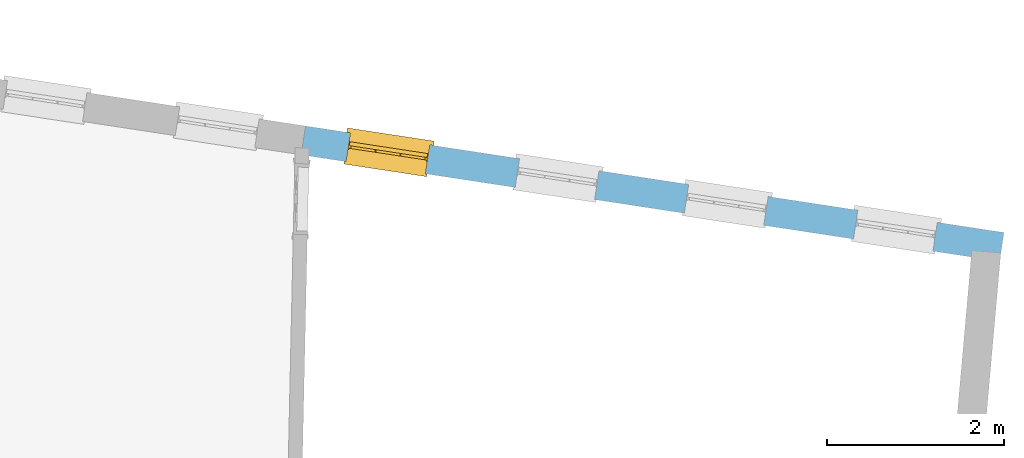
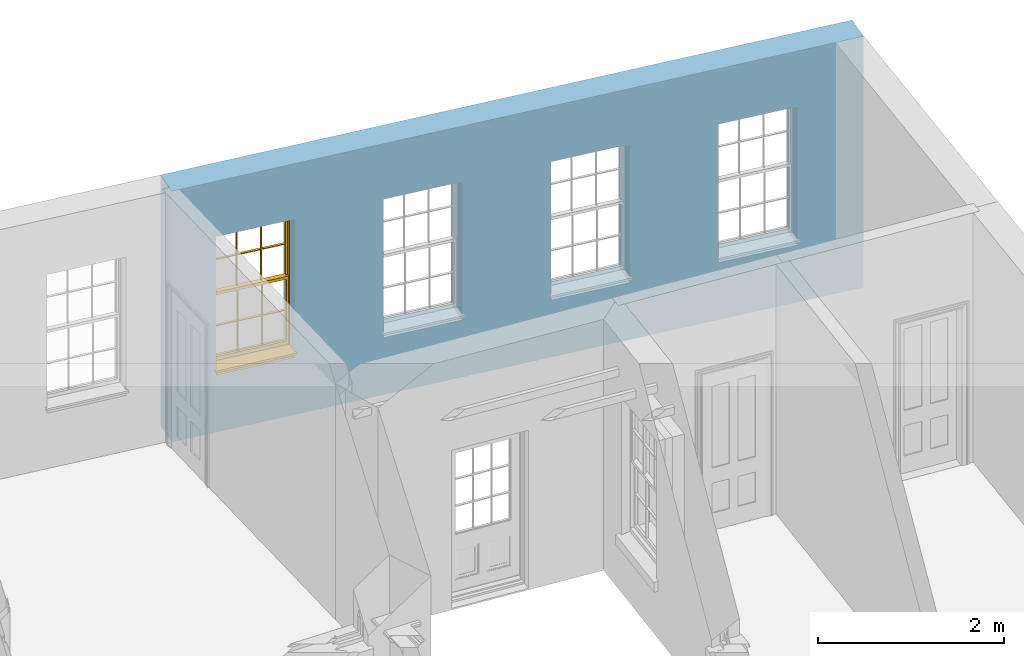
# One storey, part 10 of 12: 1 window, 4 openings, plus 1 element that does not belong to this part.
"""IFC2X3 building model written with IfcOpenShell, lengths in metres."""

from ifc_helpers import new_model, si_unit, frame, origin, place, context, subcontext, project, spatial, polyline, outline, extrude, faceted_brep, material, layer, layer_set, layer_usage, element, fill, save


model = new_model("IFC2X3")

# Units and contexts
model_context = context("Model", 3, world=origin())
body_context = subcontext(model_context, "Body", "Model", "MODEL_VIEW")
ifc_project = project(units=[si_unit("PLANEANGLEUNIT", "RADIAN"), si_unit("MASSUNIT", "GRAM", prefix="KILO"), si_unit("FORCEUNIT", "NEWTON", prefix="KILO"), si_unit("LENGTHUNIT", "METRE")], contexts=[model_context])

# Site, building, storey
site_placement = place(None, origin())
site = spatial("IfcSite", under=ifc_project, at=site_placement, CompositionType="ELEMENT")
building_placement = place(None, origin())
building = spatial("IfcBuilding", under=site, at=building_placement, Name="Building plot-18", CompositionType="ELEMENT")
storey_placement = place(None, frame((0.0, 0.0, 6.6)))
storey = spatial("IfcBuildingStorey", under=building, at=storey_placement, Name="Floor 1", CompositionType="ELEMENT", Elevation=6.6)

# Wall, openings, window
ifc_material = material(Name="Masonry")
ifc_layer = layer(ifc_material, 0.33, ventilated=False)
ifc_layer_set = layer_set([ifc_layer], Name="My Wall")
ifc_layer_usage = layer_usage(ifc_layer_set, "AXIS2", "NEGATIVE", 0.08)
wall_placement = place(storey_placement, origin())
wall = element("IfcWallStandardCase", 1, at=wall_placement, inside=storey, material=ifc_layer_usage, Name="exterior", context=body_context, shape_type="SweptSolid", body=[
    extrude(outline(polyline([(101.941775393575, 24.4390124661107), (101.991519769301, 24.7652416755381), (94.0844961381432, 25.9709275645287), (94.0347517624171, 25.6446983551013), (101.941775393575, 24.4390124661107)])), origin(), (0.0, 0.0, 1.0), 3.3),
])
opening_1_placement = place(storey_placement, frame((0.0, 0.0, 0.75)))
element("IfcOpeningElement", 2, at=opening_1_placement, cuts=wall, Name="Opening", ObjectType="Opening", context=body_context, shape_type="SweptSolid", body=[
    extrude(outline(polyline([(101.236692272156, 24.880339960858), (100.337090512825, 25.017513845436), (100.287346137099, 24.6912846360086), (101.186947896429, 24.5541107514306), (101.236692272156, 24.880339960858)])), origin(), (0.0, 0.0, 1.0), 1.82),
])
opening_2_placement = place(storey_placement, frame((0.0, 0.0, 0.75)))
element("IfcOpeningElement", 3, at=opening_2_placement, cuts=wall, Name="Opening", ObjectType="Opening", context=body_context, shape_type="SweptSolid", body=[
    extrude(outline(polyline([(99.3217221994849, 25.1723401498242), (98.4221204401548, 25.3095140344022), (98.3723760644287, 24.9832848249748), (99.2719778237588, 24.8461109403968), (99.3217221994849, 25.1723401498242)])), origin(), (0.0, 0.0, 1.0), 1.82),
])
opening_3_placement = place(storey_placement, frame((0.0, 0.0, 0.75)))
element("IfcOpeningElement", 4, at=opening_3_placement, cuts=wall, Name="Opening", ObjectType="Opening", context=body_context, shape_type="SweptSolid", body=[
    extrude(outline(polyline([(97.4067521268142, 25.4643403387904), (96.5071503674841, 25.6015142233684), (96.4574059917581, 25.275285013941), (97.3570077510882, 25.138111129363), (97.4067521268142, 25.4643403387904)])), origin(), (0.0, 0.0, 1.0), 1.82),
])
opening_4_placement = place(storey_placement, frame((0.0, 0.0, 0.75)))
opening_4 = element("IfcOpeningElement", 5, at=opening_4_placement, cuts=wall, Name="Opening", ObjectType="Opening", context=body_context, shape_type="SweptSolid", body=[
    extrude(outline(polyline([(95.4917820541436, 25.7563405277566), (94.5921802948135, 25.8935144123346), (94.5424359190874, 25.5672852029072), (95.4420376784175, 25.4301113183292), (95.4917820541436, 25.7563405277566)])), origin(), (0.0, 0.0, 1.0), 1.82),
])
window_placement = place(storey_placement, frame((95.4540969210178, 25.5091971872813, 0.75), z_axis=(0.0, 0.0, 1.0), x_axis=(-0.899601759330096, 0.13717388457793, 0.0)))
window = element("IfcWindow", 6, at=window_placement, inside=storey, Name="circulation outside window", OverallHeight=1.82, OverallWidth=0.91, context=body_context, shape_type="Brep", held_by="IfcProductRepresentation", body=[
    faceted_brep([(0.033125, -0.105, 0.975209), (0.01, -0.105, 0.975209), (0.033125, -0.105, 1.376042), (0.876875, -0.105, 0.975209), (0.876875, -0.105, 1.376042), (0.9, -0.105, 0.975209), (0.876875, -0.105, 1.386042), (0.876875, -0.105, 1.786875), (0.9, -0.105, 1.81), (0.033125, -0.105, 1.786875), (0.033125, -0.105, 1.386042), (0.01, -0.105, 1.81), (0.876875, -0.135, 1.376042), (0.876875, -0.135, 0.975209), (0.9, -0.135, 0.937083), (0.033125, -0.135, 1.786875), (0.01, -0.135, 1.81), (0.033125, -0.135, 1.386042), (0.01, -0.135, 0.937083), (0.033125, -0.135, 0.975209), (0.033125, -0.135, 1.376042), (0.876875, -0.135, 1.786875), (0.876875, -0.135, 1.386042), (0.9, -0.135, 1.81), (0.033125, -0.105, 0.937083), (0.01, -0.105, 0.937083), (0.033125, -0.105, 0.53625), (0.876875, -0.105, 0.937083), (0.876875, -0.105, 0.53625), (0.9, -0.105, 0.937083), (0.876875, -0.105, 0.52625), (0.876875, -0.105, 0.125417), (0.9, -0.105, 0.077167), (0.033125, -0.105, 0.125417), (0.033125, -0.105, 0.52625), (0.01, -0.105, 0.077167), (-0.0425, -0.25, 0.01), (-0.0425, -0.3, 0.001667), (0.0, -0.25, 0.01), (0.9525, -0.25, 0.01), (0.91, -0.25, 0.01), (0.9525, -0.3, 0.001667), (-0.02, 0.08, 0.077167), (0.0, 0.08, 0.077167), (-0.02, 0.11, 0.077167), (0.0, -0.06, 0.077167), (0.01, -0.06, 0.077167), (0.91, -0.06, 0.077167), (0.91, 0.08, 0.077167), (0.9, -0.06, 0.077167), (0.93, 0.08, 0.077167), (0.93, 0.11, 0.077167), (0.01, -0.075, 0.975209), (0.9, -0.075, 0.975209), (0.876875, -0.075, 0.125417), (0.876875, -0.075, 0.52625), (0.9, -0.075, 0.077167), (0.876875, -0.075, 0.53625), (0.876875, -0.075, 0.937083), (0.033125, -0.075, 0.125417), (0.01, -0.075, 0.077167), (0.033125, -0.075, 0.52625), (0.033125, -0.075, 0.937083), (0.033125, -0.075, 0.53625), (-0.02, 0.08, 0.052167), (-0.02, 0.11, 0.052167), (0.93, 0.11, 0.052167), (0.93, 0.08, 0.052167), (0.91, 0.08, 0.052167), (0.0, 0.08, 0.052167), (0.91, -0.15, 0.026667), (0.0, -0.15, 0.026667), (-0.0425, -0.3, -0.123333), (0.9525, -0.3, -0.123333), (-0.0425, -0.25, -0.123333), (0.9525, -0.25, -0.123333), (0.01, -0.06, 1.81), (0.9, -0.06, 1.81), (0.0, -0.06, 1.82), (0.91, -0.06, 1.82), (0.01, -0.15, 0.077167), (0.9, -0.15, 0.077167), (0.592292, -0.105, 0.125417), (0.592292, -0.075, 0.125417), (0.317708, -0.075, 0.125417), (0.317708, -0.105, 0.125417), (0.592292, -0.105, 0.53625), (0.317708, -0.105, 0.53625), (0.317708, -0.105, 0.52625), (0.592292, -0.105, 0.52625), (0.592292, -0.075, 0.53625), (0.317708, -0.075, 0.53625), (0.592292, -0.135, 1.386042), (0.592292, -0.105, 1.386042), (0.317708, -0.105, 1.386042), (0.317708, -0.135, 1.386042), (0.317708, -0.135, 1.376042), (0.592292, -0.135, 1.376042), (0.317708, -0.105, 1.376042), (0.592292, -0.105, 1.376042), (0.602292, -0.135, 1.376042), (0.592292, -0.135, 0.975209), (0.602292, -0.135, 0.975209), (0.602292, -0.105, 0.975209), (0.592292, -0.105, 0.975209), (0.602292, -0.105, 1.376042), (0.602292, -0.075, 0.53625), (0.602292, -0.105, 0.53625), (0.317708, -0.075, 0.52625), (0.307708, -0.075, 0.125417), (0.307708, -0.075, 0.52625), (0.602292, -0.075, 0.52625), (0.602292, -0.075, 0.125417), (0.592292, -0.075, 0.52625), (0.307708, -0.075, 0.53625), (0.317708, -0.075, 0.937083), (0.307708, -0.075, 0.937083), (0.602292, -0.075, 0.937083), (0.592292, -0.075, 0.937083), (0.307708, -0.105, 0.52625), (0.307708, -0.105, 0.125417), (0.307708, -0.105, 0.53625), (0.307708, -0.105, 0.937083), (0.592292, -0.105, 0.937083), (0.317708, -0.105, 0.937083), (0.602292, -0.105, 0.937083), (0.602292, -0.105, 0.52625), (0.602292, -0.105, 0.125417), (0.307708, -0.135, 1.386042), (0.307708, -0.135, 1.376042), (0.307708, -0.135, 0.975209), (0.317708, -0.135, 0.975209), (0.317708, -0.135, 1.786875), (0.307708, -0.135, 1.786875), (0.602292, -0.135, 1.786875), (0.592292, -0.135, 1.786875), (0.602292, -0.135, 1.386042), (0.602292, -0.105, 1.386042), (0.307708, -0.105, 1.386042), (0.307708, -0.105, 1.786875), (0.317708, -0.105, 1.786875), (0.592292, -0.105, 1.786875), (0.602292, -0.105, 1.786875), (0.307708, -0.105, 1.376042), (0.317708, -0.105, 0.975209), (0.307708, -0.105, 0.975209), (0.91, -0.15, 1.82), (0.9, -0.15, 1.81), (0.01, -0.15, 1.81), (0.0, -0.15, 1.82), (0.91, -0.25, 0.0), (0.0, -0.25, 0.0), (0.91, 0.08, 0.0), (0.0, 0.08, 0.0)], [[[0, 1, 2]], [[3, 4, 5]], [[6, 7, 8]], [[9, 10, 11]], [[12, 13, 14]], [[15, 16, 17]], [[18, 19, 20]], [[21, 22, 23]], [[24, 25, 26]], [[27, 28, 29]], [[30, 31, 32]], [[33, 34, 35]], [[14, 27, 29]], [[25, 24, 18]], [[36, 37, 38]], [[39, 40, 41]], [[42, 43, 44]], [[45, 46, 43]], [[47, 48, 49]], [[50, 51, 48]], [[1, 0, 52]], [[5, 53, 3]], [[54, 55, 56]], [[57, 58, 53]], [[59, 60, 61]], [[62, 63, 52]], [[48, 43, 46, 49]], [[51, 44, 43, 48]], [[64, 42, 44, 65]], [[65, 44, 51, 66]], [[66, 51, 50, 67]], [[65, 66, 68, 69]], [[60, 56, 49, 46]], [[70, 71, 38, 40]], [[37, 41, 40, 38]], [[37, 72, 73, 41]], [[74, 75, 73, 72]], [[8, 11, 76, 77]], [[76, 78, 79, 77]], [[32, 35, 80, 81]], [[81, 80, 71, 70]], [[82, 83, 84, 85]], [[86, 87, 88, 89]], [[86, 90, 91, 87]], [[92, 93, 94, 95]], [[92, 95, 96, 97]], [[96, 98, 99, 97]], [[100, 97, 101, 102]], [[103, 104, 99, 105]], [[97, 99, 104, 101]], [[102, 103, 105, 100]], [[28, 57, 106, 107]], [[108, 84, 109, 110]], [[111, 112, 83, 113]], [[114, 110, 61, 63]], [[90, 113, 108, 91]], [[115, 91, 114, 116]], [[117, 106, 90, 118]], [[111, 106, 57, 55]], [[119, 110, 109, 120]], [[34, 61, 110, 119]], [[89, 113, 83, 82]], [[88, 108, 113, 89]], [[85, 84, 108, 88]], [[121, 114, 63, 26]], [[122, 116, 114, 121]], [[123, 118, 90, 86]], [[87, 91, 115, 124]], [[107, 106, 117, 125]], [[126, 111, 55, 30]], [[127, 112, 111, 126]], [[126, 30, 28, 107]], [[88, 119, 120, 85]], [[126, 89, 82, 127]], [[125, 123, 86, 107]], [[121, 26, 34, 119]], [[124, 122, 121, 87]], [[128, 17, 20, 129]], [[96, 129, 130, 131]], [[132, 133, 128, 95]], [[134, 135, 92, 136]], [[100, 12, 22, 136]], [[137, 6, 4, 105]], [[94, 138, 139, 140]], [[137, 93, 141, 142]], [[99, 98, 94, 93]], [[143, 2, 10, 138]], [[144, 145, 143, 98]], [[129, 143, 145, 130]], [[20, 2, 143, 129]], [[131, 144, 98, 96]], [[128, 138, 10, 17]], [[133, 139, 138, 128]], [[135, 141, 93, 92]], [[95, 94, 140, 132]], [[22, 6, 137, 136]], [[136, 137, 142, 134]], [[100, 105, 4, 12]], [[107, 86, 89, 126]], [[106, 111, 113, 90]], [[91, 108, 110, 114]], [[87, 121, 119, 88]], [[97, 100, 136, 92]], [[129, 96, 95, 128]], [[98, 143, 138, 94]], [[105, 99, 93, 137]], [[131, 101, 104, 144]], [[124, 115, 118, 123]], [[132, 140, 141, 135]], [[120, 109, 59, 33]], [[15, 9, 139, 133]], [[134, 142, 7, 21]], [[31, 54, 112, 127]], [[36, 74, 72, 37]], [[39, 41, 73, 75]], [[18, 14, 101, 131]], [[23, 16, 132, 135]], [[83, 56, 60, 84]], [[52, 53, 118, 115]], [[53, 52, 144, 104]], [[11, 8, 141, 140]], [[14, 18, 124, 123]], [[2, 1, 11, 10]], [[8, 5, 4, 6]], [[57, 53, 56, 55]], [[60, 52, 63, 61]], [[26, 25, 35, 34]], [[32, 29, 28, 30]], [[14, 23, 22, 12]], [[18, 20, 17, 16]], [[19, 0, 2, 20]], [[17, 10, 9, 15]], [[12, 4, 3, 13]], [[21, 7, 6, 22]], [[27, 58, 57, 28]], [[30, 55, 54, 31]], [[33, 59, 61, 34]], [[26, 63, 62, 24]], [[5, 8, 77, 53]], [[76, 11, 1, 52]], [[46, 45, 78, 76]], [[49, 77, 79, 47]], [[70, 146, 147, 81]], [[71, 80, 148, 149]], [[19, 130, 145, 0]], [[102, 13, 3, 103]], [[116, 122, 24, 62]], [[29, 32, 81, 14]], [[80, 35, 25, 18]], [[60, 46, 76, 52]], [[77, 49, 56, 53]], [[23, 14, 81, 147]], [[16, 148, 80, 18]], [[35, 85, 120]], [[120, 33, 35]], [[127, 82, 32]], [[32, 31, 127]], [[32, 82, 85, 35]], [[102, 101, 14]], [[14, 13, 102]], [[18, 131, 130]], [[130, 19, 18]], [[134, 21, 23]], [[23, 135, 134]], [[16, 15, 133]], [[133, 132, 16]], [[11, 140, 139]], [[139, 9, 11]], [[142, 141, 8]], [[8, 7, 142]], [[23, 147, 148, 16]], [[146, 149, 148, 147]], [[52, 115, 116]], [[116, 62, 52]], [[118, 53, 117]], [[58, 117, 53]], [[27, 125, 117, 58]], [[56, 83, 112]], [[112, 54, 56]], [[109, 84, 60]], [[60, 59, 109]], [[125, 27, 14]], [[14, 123, 125]], [[122, 124, 18]], [[18, 24, 122]], [[145, 144, 52]], [[52, 0, 145]], [[103, 3, 53]], [[53, 104, 103]], [[79, 78, 149, 146]], [[78, 45, 71, 149]], [[146, 70, 47, 79]], [[150, 75, 74, 151]], [[68, 66, 67]], [[48, 68, 67, 50]], [[69, 64, 65]], [[42, 64, 69, 43]], [[69, 68, 152, 153]], [[70, 68, 48, 47]], [[150, 152, 68, 70]], [[43, 69, 71, 45]], [[69, 153, 151, 71]], [[152, 150, 151, 153]], [[38, 151, 74, 36]], [[71, 151, 38]], [[39, 75, 150, 40]], [[40, 150, 70]]]),
])
fill(opening_4, window)

save(model, "model.ifc")
